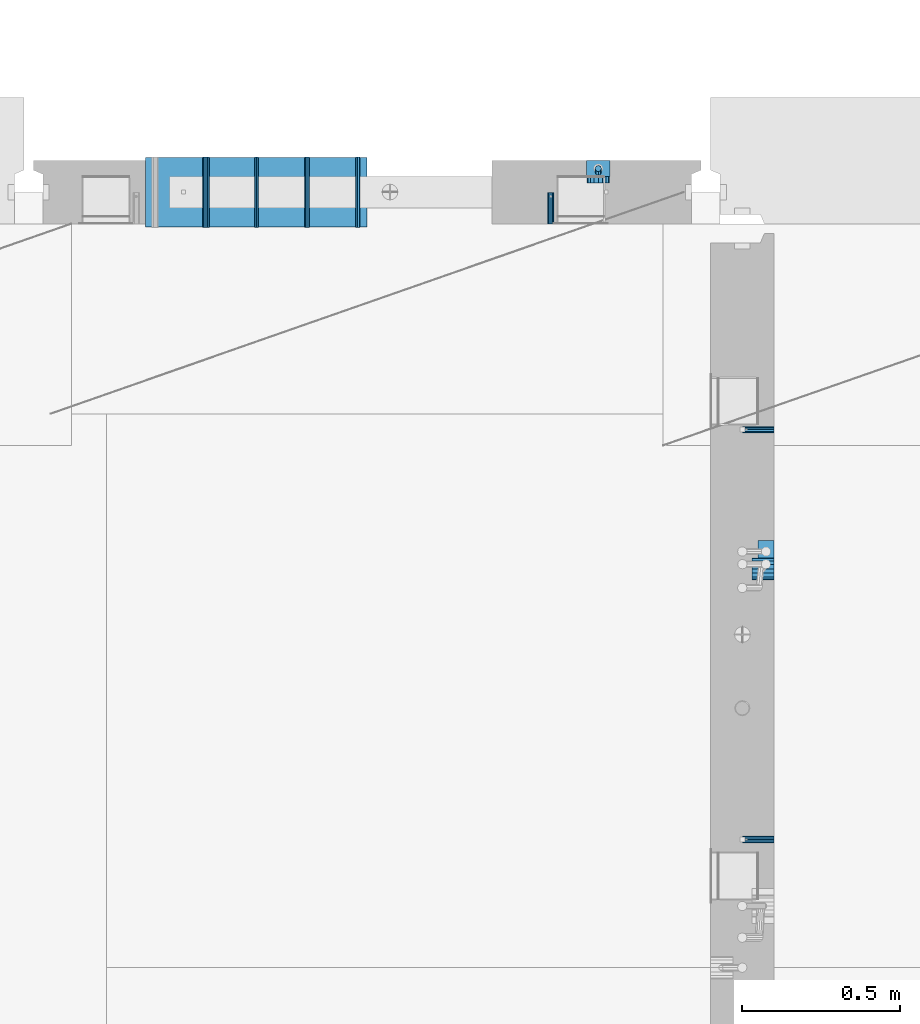
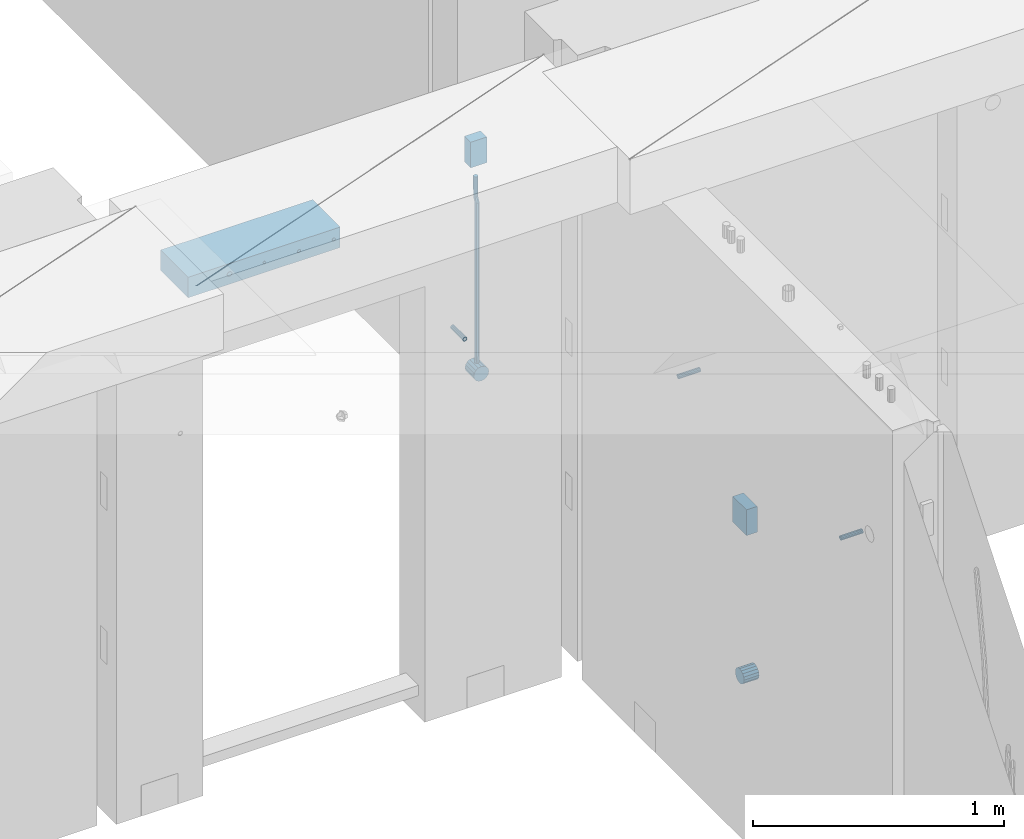
# One storey, part 125 of 309: 13 beams, 5 elements without a shape of their own.
"""IFC2X3 building model written with IfcOpenShell, lengths in millimetres."""

import ifcopenshell
import ifcopenshell.guid

model = None  # the IFC model being written
_history = None  # IfcOwnerHistory: only IFC2X3 demands one
_inside = {}  # id of a spatial element -> (the spatial element, [elements in it])
_under = {}  # id of a project, library or spatial element -> (it, [spatial elements below it])
_declared = {}  # id of a project -> (the project, [libraries it declares])
_typed = {}  # id of a type object -> (the type object, [elements of that type])
_made_of = {}  # id of a material, layer set ... -> (it, [elements and type objects made of it])


def new_model(schema):
    """Start an empty IFC model of exactly this schema.

    Asked for "IFC4X3", IfcOpenShell would pick the latest addendum, in which some entities
    have other attributes; the version numbers below select the first issue.
    IFC2X3 requires an IfcOwnerHistory on every rooted entity: one is made here for all.
    """
    global model, _history
    if schema == "IFC4X3":
        model = ifcopenshell.file(schema_version=(4, 3, 0, 0))
    else:
        model = ifcopenshell.file(schema=schema)
    _inside.clear()
    _under.clear()
    _declared.clear()
    _typed.clear()
    _made_of.clear()
    _history = None
    if model.schema == "IFC2X3":
        org = make("IfcOrganization", Name="unknown")
        user = make(
            "IfcPersonAndOrganization",
            ThePerson=make("IfcPerson", FamilyName="unknown"),
            TheOrganization=org,
        )
        app = make(
            "IfcApplication",
            ApplicationDeveloper=org,
            Version="unknown",
            ApplicationFullName="unknown",
            ApplicationIdentifier="unknown",
        )
        _history = make(
            "IfcOwnerHistory",
            OwningUser=user,
            OwningApplication=app,
            ChangeAction="ADDED",
            CreationDate=0,
        )
    return model


def make(cls, **values):
    """One entity of the class cls with the attributes given. An attribute that is None is left unset."""
    return model.create_entity(
        cls, **{name: value for name, value in values.items() if value is not None}
    )


def rooted(cls, **values):
    """An entity with a GlobalId (a new one), such as an element, a storey or a relation."""
    return make(cls, GlobalId=ifcopenshell.guid.new(), OwnerHistory=_history, **values)


def si_unit(unit_type, name, prefix=None):
    """IfcSIUnit, for example si_unit("LENGTHUNIT", "METRE", prefix="MILLI")."""
    return make("IfcSIUnit", UnitType=unit_type, Prefix=prefix, Name=name)


def assignment(units):
    """IfcUnitAssignment: the units of a project."""
    return None if units is None else make("IfcUnitAssignment", Units=units)


def point(xyz):
    """IfcCartesianPoint."""
    return None if xyz is None else make("IfcCartesianPoint", Coordinates=xyz)


def direction(xyz):
    """IfcDirection."""
    return None if xyz is None else make("IfcDirection", DirectionRatios=xyz)


def frame(location, z_axis=None, x_axis=None):
    """IfcAxis2Placement3D, a coordinate frame: its origin and axes. An axis left out is left unset."""
    return make(
        "IfcAxis2Placement3D",
        Location=point(location),
        Axis=direction(z_axis),
        RefDirection=direction(x_axis),
    )


def origin_with_axes():
    """The frame at (0, 0, 0) with the z axis (0, 0, 1) and the x axis (1, 0, 0) written out."""
    return frame((0.0, 0.0, 0.0), z_axis=(0.0, 0.0, 1.0), x_axis=(1.0, 0.0, 0.0))


def place(relative_to, where):
    """IfcLocalPlacement: puts the frame where relative to a parent placement (None: the world)."""
    return make(
        "IfcLocalPlacement", PlacementRelTo=relative_to, RelativePlacement=where
    )


def context(
    kind, dimensions, precision=None, world=None, true_north=None, identifier=None
):
    """IfcGeometricRepresentationContext, for example the 3D "Model" context."""
    return make(
        "IfcGeometricRepresentationContext",
        ContextIdentifier=identifier,
        ContextType=kind,
        CoordinateSpaceDimension=dimensions,
        Precision=precision,
        WorldCoordinateSystem=world,
        TrueNorth=true_north,
    )


def subcontext(parent, identifier, kind, view, scale=None):
    """IfcGeometricRepresentationSubContext, for example "Body" below "Model"."""
    return make(
        "IfcGeometricRepresentationSubContext",
        ContextIdentifier=identifier,
        ContextType=kind,
        ParentContext=parent,
        TargetScale=scale,
        TargetView=view,
    )


def project(units=None, contexts=None):
    """IfcProject with its units and contexts."""
    return rooted(
        "IfcProject",
        Name="project",
        RepresentationContexts=contexts,
        UnitsInContext=assignment(units),
    )


def spatial(cls, under=None, at=None, **own):
    """A site, building, storey or space (cls), placed at a placement, below another one or the project."""
    s = rooted(cls, ObjectPlacement=at, **own)
    if under is not None:
        _under.setdefault(under.id(), (under, []))[1].append(s)
    return s


def faces_of(points, faces, orient=None, outer=None):
    """IfcFace entities. A face is a list of loops; a loop is a list of indices into points, from 0.

    orient and outer hold one flag for each loop. By default every Orientation is true, the
    first loop of a face is its IfcFaceOuterBound and the others are IfcFaceBound.
    """
    made = []
    for i, loops in enumerate(faces):
        bounds = []
        for j, loop in enumerate(loops):
            is_outer = j == 0 if outer is None else outer[i][j]
            bounds.append(
                make(
                    "IfcFaceOuterBound" if is_outer else "IfcFaceBound",
                    Bound=make("IfcPolyLoop", Polygon=[points[k] for k in loop]),
                    Orientation=True if orient is None else orient[i][j],
                )
            )
        made.append(make("IfcFace", Bounds=bounds))
    return made


def faceted_brep(points, faces, orient=None, outer=None, voids=None):
    """IfcFacetedBrep: a solid bounded by flat faces; with voids (closed shells), ...WithVoids."""
    shared = [point(p) for p in points]
    hull = make("IfcClosedShell", CfsFaces=faces_of(shared, faces, orient, outer))
    if voids is None:
        return make("IfcFacetedBrep", Outer=hull)
    return make(
        "IfcFacetedBrepWithVoids",
        Outer=hull,
        Voids=[
            make(cls, CfsFaces=faces_of(shared, fs, o, b)) for cls, fs, o, b in voids
        ],
    )


def shape(context_of_items, identifier, shape_type, items):
    """IfcShapeRepresentation: the items that make up one representation, for example the "Body"."""
    return make(
        "IfcShapeRepresentation",
        ContextOfItems=context_of_items,
        RepresentationIdentifier=identifier,
        RepresentationType=shape_type,
        Items=items,
    )


def material(Name=None, Category=None):
    """IfcMaterial."""
    return make("IfcMaterial", Name=Name, Category=Category)


def made_of(thing, what):
    """Note that an element or type object is made of a material, layer set ...; save() writes the relation."""
    if what is not None:
        _made_of.setdefault(what.id(), (what, []))[1].append(thing)
    return thing


def type_object(cls, material=None, **own):
    """A type object (cls), such as IfcWallType, which elements share."""
    return made_of(rooted(cls, **own), material)


def element(
    cls,
    number,
    at=None,
    inside=None,
    cuts=None,
    type_object=None,
    material=None,
    context=None,
    identifier="Body",
    shape_type=None,
    held_by="IfcProductDefinitionShape",
    body=None,
    shapes=None,
    **own,
):
    """One element of the class cls, such as IfcWall. Its Tag is "e" and its number.

    at: its placement. inside: the storey or other place that contains it. cuts: it is an
    opening in that element (IfcRelVoidsElement). A single representation is given by context,
    identifier, shape_type and body (its items); several are given by shapes. held_by: the class
    of the entity that holds the representations. save() writes the other relations.
    """
    e = rooted(cls, Tag="e%d" % number, ObjectPlacement=at, **own)
    if body is not None:
        shapes = [shape(context, identifier, shape_type, body)]
    if shapes is not None:
        e.Representation = make(held_by, Representations=shapes)
    if inside is not None:
        _inside.setdefault(inside.id(), (inside, []))[1].append(e)
    if cuts is not None:
        rooted(
            "IfcRelVoidsElement", RelatingBuildingElement=cuts, RelatedOpeningElement=e
        )
    if type_object is not None:
        _typed.setdefault(type_object.id(), (type_object, []))[1].append(e)
    return made_of(e, material)


def aggregate(whole, parts):
    """IfcRelAggregates: a whole, such as a stair, and the parts it consists of."""
    return rooted("IfcRelAggregates", RelatingObject=whole, RelatedObjects=parts)


def save(model, path):
    """Write the relations noted so far, then the file.

    IfcRelAggregates (storeys below a building ...), IfcRelContainedInSpatialStructure (elements
    in a storey), IfcRelDefinesByType, IfcRelAssociatesMaterial and IfcRelDeclares: one each for
    every whole, place, type object, material and project.
    """
    for whole, parts in _under.values():
        aggregate(whole, parts)
    for where, things in _inside.values():
        rooted(
            "IfcRelContainedInSpatialStructure",
            RelatedElements=things,
            RelatingStructure=where,
        )
    for kind, things in _typed.values():
        rooted("IfcRelDefinesByType", RelatedObjects=things, RelatingType=kind)
    for what, things in _made_of.values():
        rooted("IfcRelAssociatesMaterial", RelatedObjects=things, RelatingMaterial=what)
    for by, libraries in _declared.values():
        rooted("IfcRelDeclares", RelatingContext=by, RelatedDefinitions=libraries)
    model.write(path)


model = new_model("IFC2X3")

# Units and contexts
model_context = context("Model", 3, precision=1e-05, world=origin_with_axes())
body_context = subcontext(model_context, "Body", "Model", "MODEL_VIEW")
ifc_project = project(units=[si_unit("LENGTHUNIT", "METRE", prefix="MILLI"), si_unit("AREAUNIT", "SQUARE_METRE"), si_unit("VOLUMEUNIT", "CUBIC_METRE"), si_unit("MASSUNIT", "GRAM", prefix="KILO"), si_unit("TIMEUNIT", "SECOND"), si_unit("PLANEANGLEUNIT", "RADIAN"), si_unit("SOLIDANGLEUNIT", "STERADIAN"), si_unit("THERMODYNAMICTEMPERATUREUNIT", "DEGREE_CELSIUS"), si_unit("LUMINOUSINTENSITYUNIT", "LUMEN")], contexts=[model_context])

# Site, building, storey
site_placement = place(None, origin_with_axes())
site = spatial("IfcSite", under=ifc_project, at=site_placement, CompositionType="ELEMENT")
building_placement = place(site_placement, origin_with_axes())
building = spatial("IfcBuilding", under=site, at=building_placement, CompositionType="ELEMENT")
storey_placement = place(building_placement, origin_with_axes())
storey = spatial("IfcBuildingStorey", under=building, at=storey_placement, Name="7", CompositionType="ELEMENT", Elevation=0.0)

# Assemblies, beams
assembly_1_placement = place(storey_placement, origin_with_axes())
assembly_1 = element("IfcElementAssembly", 1, at=assembly_1_placement, inside=storey, AssemblyPlace="NOTDEFINED", PredefinedType="REINFORCEMENT_UNIT")
assembly_2_placement = place(assembly_1_placement, origin_with_axes())
assembly_2 = element("IfcElementAssembly", 2, at=assembly_2_placement, Name="Steel Assembly", AssemblyPlace="NOTDEFINED", PredefinedType="RIGID_FRAME")
ifc_material_1 = material(Name="STEEL/Steel_Undefined")
beam_type_1 = type_object("IfcBeamType", PredefinedType="NOTDEFINED")
beam_1_placement = place(assembly_2_placement, frame((21910.0, 13134.9999119588, 101555.0), z_axis=(0.0, -1.0, 0.0), x_axis=(-1.0, 3.00000001838171e-08, 0.0)))
beam_1 = element("IfcBeam", 3, at=beam_1_placement, type_object=beam_type_1, material=ifc_material_1, Name="M16", context=body_context, shape_type="Brep", body=[
    faceted_brep([(0.0, -8.49999999999272, -1.45519152283669e-11), (0.0, -7.36121593215648, 4.24999999998545), (100.000000000262, -7.36121593215648, 4.24999999998545), (100.000000000262, -8.49999999999272, -1.45519152283669e-11), (0.0, -4.24999999998545, 7.36121593216376), (100.000000000262, -4.24999999998545, 7.36121593216376), (0.0, 1.45519152283669e-11, 8.49999999998545), (100.000000000262, 1.45519152283669e-11, 8.49999999998545), (0.0, 4.25000000001455, 7.36121593216376), (100.000000000262, 4.25000000001455, 7.36121593216376), (0.0, 7.36121593217104, 4.24999999998545), (100.000000000262, 7.36121593217104, 4.24999999998545), (0.0, 8.50000000000728, 0.0), (100.000000000262, 8.50000000000728, 0.0), (0.0, 7.36121593217104, -4.25000000001455), (100.000000000262, 7.36121593217104, -4.25000000001455), (0.0, 4.25000000000728, -7.36121593219286), (100.000000000262, 4.25000000000728, -7.36121593219286), (0.0, 7.27595761418343e-12, -8.5), (100.000000000262, 7.27595761418343e-12, -8.5), (0.0, -4.24999999999272, -7.36121593217831), (100.000000000262, -4.24999999999272, -7.36121593217831), (0.0, -7.36121593215648, -4.25), (100.000000000262, -7.36121593215648, -4.25), (0.0, -10.4999999999927, -1.45519152283669e-11), (0.0, -9.09326673972828, -5.25000000001455), (100.000000000262, -9.09326673972828, -5.25000000001455), (100.000000000262, -10.4999999999927, -1.45519152283669e-11), (0.0, -5.24999999998545, -9.09326673974283), (100.000000000262, -5.24999999998545, -9.09326673974283), (0.0, 7.27595761418343e-12, -10.5), (100.000000000262, 7.27595761418343e-12, -10.5), (0.0, 5.25000000001455, -9.09326673975738), (100.000000000262, 5.25000000001455, -9.09326673975738), (0.0, 9.09326673975011, -5.25000000001455), (100.000000000262, 9.09326673975011, -5.25000000001455), (0.0, 10.5000000000073, -1.45519152283669e-11), (100.000000000262, 10.5000000000073, -1.45519152283669e-11), (0.0, 9.09326673975011, 5.25), (100.000000000262, 9.09326673975011, 5.25), (0.0, 5.25000000000728, 9.09326673972828), (100.000000000262, 5.25000000000728, 9.09326673972828), (0.0, 1.45519152283669e-11, 10.4999999999854), (100.000000000262, 1.45519152283669e-11, 10.4999999999854), (0.0, -5.24999999999272, 9.09326673972828), (100.000000000262, -5.24999999999272, 9.09326673972828), (0.0, -9.09326673972828, 5.24999999998545), (100.000000000262, -9.09326673972828, 5.24999999998545)], [[[0, 1, 2, 3]], [[1, 4, 5, 2]], [[4, 6, 7, 5]], [[6, 8, 9, 7]], [[8, 10, 11, 9]], [[10, 12, 13, 11]], [[12, 14, 15, 13]], [[14, 16, 17, 15]], [[16, 18, 19, 17]], [[18, 20, 21, 19]], [[20, 22, 23, 21]], [[22, 0, 3, 23]], [[24, 25, 26, 27]], [[25, 28, 29, 26]], [[28, 30, 31, 29]], [[30, 32, 33, 31]], [[32, 34, 35, 33]], [[34, 36, 37, 35]], [[36, 38, 39, 37]], [[38, 40, 41, 39]], [[40, 42, 43, 41]], [[42, 44, 45, 43]], [[44, 46, 47, 45]], [[46, 24, 27, 47]], [[29, 31, 33, 35, 37, 39, 41, 43, 45, 47, 27, 26], [5, 7, 9, 11, 13, 15, 17, 19, 21, 23, 3, 2]], [[46, 44, 42, 40, 38, 36, 34, 32, 30, 28, 25, 24], [22, 20, 18, 16, 14, 12, 10, 8, 6, 4, 1, 0]]]),
])
aggregate(assembly_2, [beam_1])
assembly_3_placement = place(assembly_1_placement, origin_with_axes())
assembly_3 = element("IfcElementAssembly", 4, at=assembly_3_placement, Name="Steel Assembly", AssemblyPlace="NOTDEFINED", PredefinedType="RIGID_FRAME")
beam_2_placement = place(assembly_3_placement, frame((21910.0, 14429.9999119589, 101555.0), z_axis=(0.0, 1.0, 0.0), x_axis=(-1.0, 3.00000001838171e-08, 0.0)))
beam_2 = element("IfcBeam", 5, at=beam_2_placement, type_object=beam_type_1, material=ifc_material_1, Name="M16", context=body_context, shape_type="Brep", body=[
    faceted_brep([(0.0, -8.49999999999272, -1.45519152283669e-11), (0.0, -7.36121593215648, 4.24999999998545), (100.000000000262, -7.36121593215648, 4.24999999998545), (100.000000000262, -8.49999999999272, -1.45519152283669e-11), (0.0, -4.24999999998545, 7.36121593216376), (100.000000000262, -4.24999999998545, 7.36121593216376), (0.0, 1.45519152283669e-11, 8.49999999998545), (100.000000000262, 1.45519152283669e-11, 8.49999999998545), (0.0, 4.25000000001455, 7.36121593216376), (100.000000000262, 4.25000000001455, 7.36121593216376), (0.0, 7.36121593217104, 4.24999999998545), (100.000000000262, 7.36121593217104, 4.24999999998545), (0.0, 8.50000000000728, 0.0), (100.000000000262, 8.50000000000728, 0.0), (0.0, 7.36121593217104, -4.25000000001455), (100.000000000262, 7.36121593217104, -4.25000000001455), (0.0, 4.25000000000728, -7.36121593219286), (100.000000000262, 4.25000000000728, -7.36121593219286), (0.0, 7.27595761418343e-12, -8.5), (100.000000000262, 7.27595761418343e-12, -8.5), (0.0, -4.24999999999272, -7.36121593217831), (100.000000000262, -4.24999999999272, -7.36121593217831), (0.0, -7.36121593215648, -4.25), (100.000000000262, -7.36121593215648, -4.25), (0.0, -10.4999999999927, -1.45519152283669e-11), (0.0, -9.09326673972828, -5.25000000001455), (100.000000000262, -9.09326673972828, -5.25000000001455), (100.000000000262, -10.4999999999927, -1.45519152283669e-11), (0.0, -5.24999999998545, -9.09326673974283), (100.000000000262, -5.24999999998545, -9.09326673974283), (0.0, 7.27595761418343e-12, -10.5), (100.000000000262, 7.27595761418343e-12, -10.5), (0.0, 5.25000000001455, -9.09326673975738), (100.000000000262, 5.25000000001455, -9.09326673975738), (0.0, 9.09326673975011, -5.25000000001455), (100.000000000262, 9.09326673975011, -5.25000000001455), (0.0, 10.5000000000073, -1.45519152283669e-11), (100.000000000262, 10.5000000000073, -1.45519152283669e-11), (0.0, 9.09326673975011, 5.25), (100.000000000262, 9.09326673975011, 5.25), (0.0, 5.25000000000728, 9.09326673972828), (100.000000000262, 5.25000000000728, 9.09326673972828), (0.0, 1.45519152283669e-11, 10.4999999999854), (100.000000000262, 1.45519152283669e-11, 10.4999999999854), (0.0, -5.24999999999272, 9.09326673972828), (100.000000000262, -5.24999999999272, 9.09326673972828), (0.0, -9.09326673972828, 5.24999999998545), (100.000000000262, -9.09326673972828, 5.24999999998545)], [[[0, 1, 2, 3]], [[1, 4, 5, 2]], [[4, 6, 7, 5]], [[6, 8, 9, 7]], [[8, 10, 11, 9]], [[10, 12, 13, 11]], [[12, 14, 15, 13]], [[14, 16, 17, 15]], [[16, 18, 19, 17]], [[18, 20, 21, 19]], [[20, 22, 23, 21]], [[22, 0, 3, 23]], [[24, 25, 26, 27]], [[25, 28, 29, 26]], [[28, 30, 31, 29]], [[30, 32, 33, 31]], [[32, 34, 35, 33]], [[34, 36, 37, 35]], [[36, 38, 39, 37]], [[38, 40, 41, 39]], [[40, 42, 43, 41]], [[42, 44, 45, 43]], [[44, 46, 47, 45]], [[46, 24, 27, 47]], [[29, 31, 33, 35, 37, 39, 41, 43, 45, 47, 27, 26], [5, 7, 9, 11, 13, 15, 17, 19, 21, 23, 3, 2]], [[46, 44, 42, 40, 38, 36, 34, 32, 30, 28, 25, 24], [22, 20, 18, 16, 14, 12, 10, 8, 6, 4, 1, 0]]]),
])
aggregate(assembly_3, [beam_2])

assembly_4_placement = place(storey_placement, origin_with_axes())
assembly_4 = element("IfcElementAssembly", 6, at=assembly_4_placement, inside=storey, AssemblyPlace="NOTDEFINED", PredefinedType="REINFORCEMENT_UNIT")
assembly_5_placement = place(assembly_4_placement, origin_with_axes())
assembly_5 = element("IfcElementAssembly", 7, at=assembly_5_placement, Name="Steel Assembly", AssemblyPlace="NOTDEFINED", PredefinedType="RIGID_FRAME")
beam_3_placement = place(assembly_5_placement, frame((21205.004085231, 15080.0, 101555.0), z_axis=(1.0, 0.0, 0.0), x_axis=(0.0, 1.0, 0.0)))
beam_3 = element("IfcBeam", 8, at=beam_3_placement, type_object=beam_type_1, material=ifc_material_1, Name="M16", context=body_context, shape_type="Brep", body=[
    faceted_brep([(0.0, -8.49999999999272, -1.45519152283669e-11), (0.0, -7.36121593215648, 4.24999999998545), (100.000000000262, -7.36121593215648, 4.24999999998545), (100.000000000262, -8.49999999999272, -1.45519152283669e-11), (0.0, -4.24999999998545, 7.36121593216376), (100.000000000262, -4.24999999998545, 7.36121593216376), (0.0, 1.45519152283669e-11, 8.49999999998545), (100.000000000262, 1.45519152283669e-11, 8.49999999998545), (0.0, 4.25000000001455, 7.36121593216376), (100.000000000262, 4.25000000001455, 7.36121593216376), (0.0, 7.36121593217104, 4.24999999998545), (100.000000000262, 7.36121593217104, 4.24999999998545), (0.0, 8.50000000000728, 0.0), (100.000000000262, 8.50000000000728, 0.0), (0.0, 7.36121593217104, -4.25000000001455), (100.000000000262, 7.36121593217104, -4.25000000001455), (0.0, 4.25000000000728, -7.36121593219286), (100.000000000262, 4.25000000000728, -7.36121593219286), (0.0, 7.27595761418343e-12, -8.5), (100.000000000262, 7.27595761418343e-12, -8.5), (0.0, -4.24999999999272, -7.36121593217831), (100.000000000262, -4.24999999999272, -7.36121593217831), (0.0, -7.36121593215648, -4.25), (100.000000000262, -7.36121593215648, -4.25), (0.0, -10.4999999999927, -1.45519152283669e-11), (0.0, -9.09326673972828, -5.25000000001455), (100.000000000262, -9.09326673972828, -5.25000000001455), (100.000000000262, -10.4999999999927, -1.45519152283669e-11), (0.0, -5.24999999998545, -9.09326673974283), (100.000000000262, -5.24999999998545, -9.09326673974283), (0.0, 7.27595761418343e-12, -10.5), (100.000000000262, 7.27595761418343e-12, -10.5), (0.0, 5.25000000001455, -9.09326673975738), (100.000000000262, 5.25000000001455, -9.09326673975738), (0.0, 9.09326673975011, -5.25000000001455), (100.000000000262, 9.09326673975011, -5.25000000001455), (0.0, 10.5000000000073, -1.45519152283669e-11), (100.000000000262, 10.5000000000073, -1.45519152283669e-11), (0.0, 9.09326673975011, 5.25), (100.000000000262, 9.09326673975011, 5.25), (0.0, 5.25000000000728, 9.09326673972828), (100.000000000262, 5.25000000000728, 9.09326673972828), (0.0, 1.45519152283669e-11, 10.4999999999854), (100.000000000262, 1.45519152283669e-11, 10.4999999999854), (0.0, -5.24999999999272, 9.09326673972828), (100.000000000262, -5.24999999999272, 9.09326673972828), (0.0, -9.09326673972828, 5.24999999998545), (100.000000000262, -9.09326673972828, 5.24999999998545)], [[[0, 1, 2, 3]], [[1, 4, 5, 2]], [[4, 6, 7, 5]], [[6, 8, 9, 7]], [[8, 10, 11, 9]], [[10, 12, 13, 11]], [[12, 14, 15, 13]], [[14, 16, 17, 15]], [[16, 18, 19, 17]], [[18, 20, 21, 19]], [[20, 22, 23, 21]], [[22, 0, 3, 23]], [[24, 25, 26, 27]], [[25, 28, 29, 26]], [[28, 30, 31, 29]], [[30, 32, 33, 31]], [[32, 34, 35, 33]], [[34, 36, 37, 35]], [[36, 38, 39, 37]], [[38, 40, 41, 39]], [[40, 42, 43, 41]], [[42, 44, 45, 43]], [[44, 46, 47, 45]], [[46, 24, 27, 47]], [[29, 31, 33, 35, 37, 39, 41, 43, 45, 47, 27, 26], [5, 7, 9, 11, 13, 15, 17, 19, 21, 23, 3, 2]], [[46, 44, 42, 40, 38, 36, 34, 32, 30, 28, 25, 24], [22, 20, 18, 16, 14, 12, 10, 8, 6, 4, 1, 0]]]),
])
aggregate(assembly_5, [beam_3])
ifc_material_2 = material()
beam_type_2 = type_object("IfcBeamType", Name="D20", PredefinedType="NOTDEFINED")
beam_4_placement = place(assembly_4_placement, frame((21354.9999999958, 15245.0000022759, 101290.0), z_axis=(0.00020576299992186, -0.999642804629538, -0.0267249099901004), x_axis=(-4.30000201928125e-08, -0.0267249099948059, 0.999642825806181)))
beam_4 = element("IfcBeam", 9, at=beam_4_placement, type_object=beam_type_2, material=ifc_material_2, Name="JM20", ObjectType="D20", context=body_context, shape_type="Brep", body=[
    faceted_brep([(0.0, -10.0, 0.0), (-4.19531716033816e-08, -7.07106781186667, -7.07106781187031), (60.3581158964225, -7.07106779467358, -7.07106780560207), (60.3581159005553, -9.99999998281055, 6.26459950581193e-09), (0.0, 0.0, -10.0), (60.3581158930319, 1.71930878423154e-08, -9.9999999937354), (4.196772351861e-08, 7.07106781186303, -7.07106781186667), (60.3581158923917, 7.07106782905612, -7.07106780560207), (0.0, 10.0, 0.0), (60.3581158948509, 10.0000000171895, 6.26459950581193e-09), (4.196772351861e-08, 7.07106781185939, 7.07106781185939), (60.3581158989837, 7.07106782905612, 7.07106781813127), (0.0, 0.0, 10.0), (60.3581159023597, 1.71930878423154e-08, 10.0000000062646), (-4.19531716033816e-08, -7.07106781187031, 7.07106781185939), (60.358115903, -7.07106779467722, 7.07106781813127), (60.8972477222414, -7.07106779452079, -7.07106780554386), (60.991799419251, -9.99999998403655, 6.21366780251265e-09), (60.8581158930319, 1.7334969015792e-08, -9.99999999368447), (60.8972861483926, 7.07106782920528, -7.07106780554386), (60.9917724058905, 10.0000000159635, 6.21366780251265e-09), (61.0863241029147, 7.07106782926348, 7.07106781820403), (61.1254559321096, 1.7415004549548e-08, 10.0000000063446), (61.086285676749, -7.07106779446985, 7.07106781820403), (61.4361869218264, -7.07107072394501, -7.08547838249069), (61.6251751877571, -10.0000034255863, -0.0169367769813107), (61.35793724822, -2.69946758635342e-06, -10.0133646071736), (61.4362637644808, 7.07106489957732, -7.08547940969947), (61.6252838596702, 9.99999657411536, -0.0169382296771801), (61.8142721256008, 7.07106387247404, 7.0516033758322), (61.8925217992073, -4.15200702263974e-06, 9.97948960051872), (61.814195282961, -7.07107175104829, 7.05160440304098), (775.690073058257, -7.07495307777208, -26.1837562433175), (775.879061324187, -10.0038857794134, -19.1152146378081), (775.611823384636, -0.00388505329101463, -29.1116424680004), (775.690149900896, 7.06718254575026, -26.1837572705263), (775.8791699961, 9.99611422029193, -19.1152160905003), (776.068158262031, 7.06718151865061, -12.0466744849909), (776.146407935637, -0.00388650583045091, -9.11878826030807), (776.068081419377, -7.07495410487172, -12.0466734577822), (776.844979390982, -7.07495935530824, -26.2146370302071), (778.703176670489, -10.0039011299996, -19.1907280380728), (776.111644739809, -0.00388777008629404, -29.1250070814895), (776.932750209904, 7.0671757915552, -26.2169828873994), (778.827303353013, 9.99609819560283, -19.1940455811236), (780.685500632535, 7.06715642091513, -12.1701365889894), (781.418835283708, -0.00391516431045602, -9.25976653770704), (780.597729813613, -7.07497872594467, -12.1677907318008), (777.861329320964, -7.08852484077215, -26.7638283058368), (781.188477298943, -10.0370730804789, -20.5336763496562), (776.551501535956, -0.00975865254440578, -29.362686553719), (778.026273295982, 7.05258025600779, -26.8078751783723), (781.421743305415, 9.96146953432981, -20.595968034173), (784.74889128338, 7.01292129462308, -14.3658160779887), (786.058719068402, -0.0658448936046625, -11.7669578301065), (784.583947308391, -7.12818380215685, -14.3217692054532), (795.432392943592, -7.32305037289916, -36.2584664814858), (798.759540921557, -10.2715986126059, -30.0283145252979), (794.12256515857, -0.244284184671415, -38.8573247293643), (795.597336918581, 6.81805472388078, -36.3025133540177), (798.992806928029, 9.72694400219916, -30.0906062098184), (802.319954905994, 6.77839576249244, -23.8604542536341), (803.629782691016, -0.300370425735309, -21.2615960057519), (802.15501093099, -7.3627093342875, -23.8164073811022), (799.505846831846, -7.3774198158244, -38.4595837060842), (801.367995818946, -10.3064143349802, -31.4378100447575), (798.762755292832, -0.306218002893729, -41.3646815597422), (799.574014147365, 6.7649769840682, -38.4513366830724), (801.464398961049, 9.69395502388943, -31.4261469929661), (803.32654794812, 6.76496050473361, -24.4043733316357), (804.069639487148, -0.306241308189783, -21.4992754779851), (803.258380632629, -7.37743629515535, -24.4126203546512), (804.134608044958, -7.36363999659807, -38.5831936197719), (804.332044311042, -10.2975903644801, -31.5169642204455), (804.035512197443, -0.290521008897485, -41.5054892177468), (804.092805771987, 6.77842942390271, -38.5720098863276), (804.272926969657, 9.70231601001069, -31.5011480329304), (804.470363235741, 6.76836564212863, -24.434918633604), (804.569459083272, -0.304753345568315, -21.5126230356327), (804.512165508728, -7.37370377836123, -24.4461023670447), (901.742523775247, -7.07306129268909, -41.1897886639781), (901.939960041316, -10.0070116605639, -34.1235592646481), (901.643427927731, 5.76950078539085e-05, -44.1120842619457), (901.700721502275, 7.06900812780805, -41.1786049305338), (901.880842699946, 9.99289471391967, -34.1077430771329), (902.07827896603, 7.05894434603761, -27.0415136778065), (902.177374813546, -0.0141746416556998, -24.1192180798353), (902.120081238987, -7.08312507445589, -27.0526974112508)], [[[0, 1, 2, 3]], [[1, 4, 5, 2]], [[4, 6, 7, 5]], [[6, 8, 9, 7]], [[8, 10, 11, 9]], [[10, 12, 13, 11]], [[12, 14, 15, 13]], [[14, 0, 3, 15]], [[14, 12, 10, 8, 6, 4, 1, 0]], [[3, 2, 16, 17]], [[2, 5, 18, 16]], [[5, 7, 19, 18]], [[7, 9, 20, 19]], [[9, 11, 21, 20]], [[11, 13, 22, 21]], [[13, 15, 23, 22]], [[15, 3, 17, 23]], [[17, 16, 24, 25]], [[16, 18, 26, 24]], [[18, 19, 27, 26]], [[19, 20, 28, 27]], [[20, 21, 29, 28]], [[21, 22, 30, 29]], [[22, 23, 31, 30]], [[23, 17, 25, 31]], [[25, 24, 32, 33]], [[24, 26, 34, 32]], [[26, 27, 35, 34]], [[27, 28, 36, 35]], [[28, 29, 37, 36]], [[29, 30, 38, 37]], [[30, 31, 39, 38]], [[31, 25, 33, 39]], [[33, 32, 40, 41]], [[32, 34, 42, 40]], [[34, 35, 43, 42]], [[35, 36, 44, 43]], [[36, 37, 45, 44]], [[37, 38, 46, 45]], [[38, 39, 47, 46]], [[39, 33, 41, 47]], [[41, 40, 48, 49]], [[40, 42, 50, 48]], [[42, 43, 51, 50]], [[43, 44, 52, 51]], [[44, 45, 53, 52]], [[45, 46, 54, 53]], [[46, 47, 55, 54]], [[47, 41, 49, 55]], [[49, 48, 56, 57]], [[48, 50, 58, 56]], [[50, 51, 59, 58]], [[51, 52, 60, 59]], [[52, 53, 61, 60]], [[53, 54, 62, 61]], [[54, 55, 63, 62]], [[55, 49, 57, 63]], [[57, 56, 64, 65]], [[56, 58, 66, 64]], [[58, 59, 67, 66]], [[59, 60, 68, 67]], [[60, 61, 69, 68]], [[61, 62, 70, 69]], [[62, 63, 71, 70]], [[63, 57, 65, 71]], [[65, 64, 72, 73]], [[64, 66, 74, 72]], [[66, 67, 75, 74]], [[67, 68, 76, 75]], [[68, 69, 77, 76]], [[69, 70, 78, 77]], [[70, 71, 79, 78]], [[71, 65, 73, 79]], [[73, 72, 80, 81]], [[72, 74, 82, 80]], [[74, 75, 83, 82]], [[75, 76, 84, 83]], [[76, 77, 85, 84]], [[77, 78, 86, 85]], [[78, 79, 87, 86]], [[79, 73, 81, 87]], [[82, 83, 84, 85, 86, 87, 81, 80]]]),
])

# Beam
beam_type_3 = type_object("IfcBeamType", Name="D70", PredefinedType="NOTDEFINED")
beam_5_placement = place(assembly_1_placement, frame((21910.0000022791, 13990.0, 100355.0), z_axis=(0.0, 0.0, 1.0), x_axis=(-1.0, 3.00000001838171e-08, 0.0)))
beam_5 = element("IfcBeam", 10, at=beam_5_placement, type_object=beam_type_3, material=ifc_material_2, ObjectType="D70", context=body_context, shape_type="Brep", body=[
    faceted_brep([(0.0, -35.0, 0.0), (0.0, -32.3357836378964, -13.3939201327739), (70.0, -32.3357836378964, -13.3939201327739), (70.0, -35.0, 0.0), (0.0, -24.7487373415279, -24.7487373415352), (70.0, -24.7487373415279, -24.7487373415352), (0.0, -13.3939201327776, -32.3357836379), (70.0, -13.3939201327776, -32.3357836379), (0.0, 0.0, -35.0), (70.0, 0.0, -35.0), (0.0, 13.3939201327776, -32.3357836379), (70.0, 13.3939201327776, -32.3357836379), (0.0, 24.7487373415279, -24.7487373415352), (70.0, 24.7487373415279, -24.7487373415352), (0.0, 32.3357836378964, -13.3939201327739), (70.0, 32.3357836378964, -13.3939201327739), (0.0, 35.0, 0.0), (70.0, 35.0, 0.0), (0.0, 32.3357836378964, 13.3939201327739), (70.0, 32.3357836378964, 13.3939201327739), (0.0, 24.7487373415279, 24.7487373415352), (70.0, 24.7487373415279, 24.7487373415352), (0.0, 13.3939201327776, 32.3357836379), (70.0, 13.3939201327776, 32.3357836379), (0.0, 0.0, 35.0), (70.0, 0.0, 35.0), (0.0, -13.3939201327776, 32.3357836379), (70.0, -13.3939201327776, 32.3357836379), (0.0, -24.7487373415279, 24.7487373415352), (70.0, -24.7487373415279, 24.7487373415352), (0.0, -32.3357836378964, 13.3939201327739), (70.0, -32.3357836378964, 13.3939201327739)], [[[0, 1, 2, 3]], [[1, 4, 5, 2]], [[4, 6, 7, 5]], [[6, 8, 9, 7]], [[8, 10, 11, 9]], [[10, 12, 13, 11]], [[12, 14, 15, 13]], [[14, 16, 17, 15]], [[16, 18, 19, 17]], [[18, 20, 21, 19]], [[20, 22, 23, 21]], [[22, 24, 25, 23]], [[24, 26, 27, 25]], [[26, 28, 29, 27]], [[28, 30, 31, 29]], [[30, 0, 3, 31]], [[5, 7, 9, 11, 13, 15, 17, 19, 21, 23, 25, 27, 29, 31, 3, 2]], [[30, 28, 26, 24, 22, 20, 18, 16, 14, 12, 10, 8, 6, 4, 1, 0]]]),
])

beam_6_placement = place(assembly_4_placement, frame((21354.9999999996, 15280.0000022759, 101255.0), z_axis=(0.0, 0.0, 1.0), x_axis=(0.0, -1.0, 0.0)))
beam_6 = element("IfcBeam", 11, at=beam_6_placement, type_object=beam_type_3, material=ifc_material_2, ObjectType="D70", context=body_context, shape_type="Brep", body=[
    faceted_brep([(0.0, -35.0, 0.0), (0.0, -32.3357836378964, -13.3939201327739), (70.0, -32.3357836378964, -13.3939201327739), (70.0, -35.0, 0.0), (0.0, -24.7487373415279, -24.7487373415352), (70.0, -24.7487373415279, -24.7487373415352), (0.0, -13.3939201327776, -32.3357836379), (70.0, -13.3939201327776, -32.3357836379), (0.0, 0.0, -35.0), (70.0, 0.0, -35.0), (0.0, 13.3939201327776, -32.3357836379), (70.0, 13.3939201327776, -32.3357836379), (0.0, 24.7487373415279, -24.7487373415352), (70.0, 24.7487373415279, -24.7487373415352), (0.0, 32.3357836378964, -13.3939201327739), (70.0, 32.3357836378964, -13.3939201327739), (0.0, 35.0, 0.0), (70.0, 35.0, 0.0), (0.0, 32.3357836378964, 13.3939201327739), (70.0, 32.3357836378964, 13.3939201327739), (0.0, 24.7487373415279, 24.7487373415352), (70.0, 24.7487373415279, 24.7487373415352), (0.0, 13.3939201327776, 32.3357836379), (70.0, 13.3939201327776, 32.3357836379), (0.0, 0.0, 35.0), (70.0, 0.0, 35.0), (0.0, -13.3939201327776, 32.3357836379), (70.0, -13.3939201327776, 32.3357836379), (0.0, -24.7487373415279, 24.7487373415352), (70.0, -24.7487373415279, 24.7487373415352), (0.0, -32.3357836378964, 13.3939201327739), (70.0, -32.3357836378964, 13.3939201327739)], [[[0, 1, 2, 3]], [[1, 4, 5, 2]], [[4, 6, 7, 5]], [[6, 8, 9, 7]], [[8, 10, 11, 9]], [[10, 12, 13, 11]], [[12, 14, 15, 13]], [[14, 16, 17, 15]], [[16, 18, 19, 17]], [[18, 20, 21, 19]], [[20, 22, 23, 21]], [[22, 24, 25, 23]], [[24, 26, 27, 25]], [[26, 28, 29, 27]], [[28, 30, 31, 29]], [[30, 0, 3, 31]], [[5, 7, 9, 11, 13, 15, 17, 19, 21, 23, 25, 27, 29, 31, 3, 2]], [[30, 28, 26, 24, 22, 20, 18, 16, 14, 12, 10, 8, 6, 4, 1, 0]]]),
])

ifc_material_3 = material()
beam_type_4 = type_object("IfcBeamType", Name="D12", PredefinedType="NOTDEFINED")
beam_7_placement = place(assembly_4_placement, frame((20274.9991455079, 15068.9997314798, 102260.0), z_axis=(-1.0, 3.00000001838171e-08, 0.0), x_axis=(0.0, 1.0, 0.0)))
beam_7 = element("IfcBeam", 12, at=beam_7_placement, type_object=beam_type_4, material=ifc_material_3, Name="12", ObjectType="D12", context=body_context, shape_type="Brep", body=[
    faceted_brep([(0.0, -6.0, -1.45519152283669e-11), (0.0, -4.24264068712, -4.24264068713819), (222.000077784061, -4.24264068712364, -4.24264068712), (222.000077784061, -6.0, 0.0), (3.63797880709171e-12, 0.0, -6.0000000000291), (222.000077784061, 0.0, -6.0), (0.0, 4.24264068712, -4.24264068713819), (222.000077784061, 4.24264068712364, -4.24264068712), (0.0, 6.0, -1.45519152283669e-11), (222.000077784061, 6.0, 0.0), (0.0, 4.24264068712, 4.24264068709454), (222.000077784061, 4.24264068712364, 4.24264068712), (0.0, 0.0, 5.99999999998545), (222.000077784061, 0.0, 6.0), (0.0, -4.24264068712, 4.24264068709454), (222.000077784061, -4.24264068712364, 4.24264068712)], [[[0, 1, 2, 3]], [[1, 4, 5, 2]], [[4, 6, 7, 5]], [[6, 8, 9, 7]], [[8, 10, 11, 9]], [[10, 12, 13, 11]], [[12, 14, 15, 13]], [[14, 0, 3, 15]], [[5, 7, 9, 11, 13, 15, 3, 2]], [[14, 12, 10, 8, 6, 4, 1, 0]]]),
])

beam_type_5 = type_object("IfcBeamType", Name="D15", PredefinedType="NOTDEFINED")
beam_8_placement = place(assembly_4_placement, frame((20594.99899292, 15068.9997314793, 102260.0), z_axis=(-1.0, 3.00000001838171e-08, 0.0), x_axis=(0.0, 1.0, 0.0)))
beam_8 = element("IfcBeam", 13, at=beam_8_placement, type_object=beam_type_5, material=ifc_material_3, Name="15", ObjectType="D15", context=body_context, shape_type="Brep", body=[
    faceted_brep([(0.0, -7.5, 0.0), (0.0, -5.30330085889727, -5.30330085890091), (222.000077784061, -5.30330085889727, -5.30330085890091), (222.000077784061, -7.5, 0.0), (0.0, 1.45519152283669e-11, -7.5), (222.000077784061, 0.0, -7.5), (0.0, 5.30330085889727, -5.30330085890091), (222.000077784061, 5.30330085889727, -5.30330085890091), (0.0, 7.5, 0.0), (222.000077784061, 7.5, 0.0), (0.0, 5.30330085889727, 5.30330085890091), (222.000077784061, 5.30330085889727, 5.30330085890091), (0.0, 1.45519152283669e-11, 7.5), (222.000077784061, 0.0, 7.5), (0.0, -5.30330085889727, 5.30330085890091), (222.000077784061, -5.30330085889727, 5.30330085890091)], [[[0, 1, 2, 3]], [[1, 4, 5, 2]], [[4, 6, 7, 5]], [[6, 8, 9, 7]], [[8, 10, 11, 9]], [[10, 12, 13, 11]], [[12, 14, 15, 13]], [[14, 0, 3, 15]], [[5, 7, 9, 11, 13, 15, 3, 2]], [[14, 12, 10, 8, 6, 4, 1, 0]]]),
])

beam_9_placement = place(assembly_4_placement, frame((20434.9991455079, 15068.9997314796, 102260.0), z_axis=(-1.0, 3.00000001838171e-08, 0.0), x_axis=(0.0, 1.0, 0.0)))
beam_9 = element("IfcBeam", 14, at=beam_9_placement, type_object=beam_type_5, material=ifc_material_3, Name="15", ObjectType="D15", context=body_context, shape_type="Brep", body=[
    faceted_brep([(0.0, -7.5, 0.0), (0.0, -5.30330085889727, -5.30330085890091), (222.000077784061, -5.30330085889727, -5.30330085890091), (222.000077784061, -7.5, 0.0), (0.0, 1.45519152283669e-11, -7.5), (222.000077784061, 0.0, -7.5), (0.0, 5.30330085889727, -5.30330085890091), (222.000077784061, 5.30330085889727, -5.30330085890091), (0.0, 7.5, 0.0), (222.000077784061, 7.5, 0.0), (0.0, 5.30330085889727, 5.30330085890091), (222.000077784061, 5.30330085889727, 5.30330085890091), (0.0, 1.45519152283669e-11, 7.5), (222.000077784061, 0.0, 7.5), (0.0, -5.30330085889727, 5.30330085890091), (222.000077784061, -5.30330085889727, 5.30330085890091)], [[[0, 1, 2, 3]], [[1, 4, 5, 2]], [[4, 6, 7, 5]], [[6, 8, 9, 7]], [[8, 10, 11, 9]], [[10, 12, 13, 11]], [[12, 14, 15, 13]], [[14, 0, 3, 15]], [[5, 7, 9, 11, 13, 15, 3, 2]], [[14, 12, 10, 8, 6, 4, 1, 0]]]),
])

beam_type_6 = type_object("IfcBeamType", Name="D22", PredefinedType="NOTDEFINED")
beam_10_placement = place(assembly_4_placement, frame((20114.9991455079, 15068.9997314801, 102260.0), z_axis=(-1.0, 3.00000001838171e-08, 0.0), x_axis=(0.0, 1.0, 0.0)))
beam_10 = element("IfcBeam", 15, at=beam_10_placement, type_object=beam_type_6, material=ifc_material_3, Name="22", ObjectType="D22", context=body_context, shape_type="Brep", body=[
    faceted_brep([(0.0, -11.0, 0.0), (0.0, -9.52627944163396, -5.5), (222.000077784061, -9.52627944163396, -5.5), (222.000077784061, -11.0, 0.0), (0.0, -5.5, -9.52627944163032), (222.000077784061, -5.5, -9.52627944163032), (0.0, 0.0, -11.0), (222.000077784061, 0.0, -11.0), (0.0, 5.5, -9.52627944163032), (222.000077784061, 5.5, -9.52627944163032), (0.0, 9.52627944163396, -5.5), (222.000077784061, 9.52627944163396, -5.5), (0.0, 11.0, 0.0), (222.000077784061, 11.0, 0.0), (0.0, 9.52627944163396, 5.5), (222.000077784061, 9.52627944163396, 5.5), (0.0, 5.5, 9.52627944163032), (222.000077784061, 5.5, 9.52627944163032), (0.0, 0.0, 11.0), (222.000077784061, 0.0, 11.0), (0.0, -5.5, 9.52627944163032), (222.000077784061, -5.5, 9.52627944163032), (0.0, -9.52627944163396, 5.5), (222.000077784061, -9.52627944163396, 5.5)], [[[0, 1, 2, 3]], [[1, 4, 5, 2]], [[4, 6, 7, 5]], [[6, 8, 9, 7]], [[8, 10, 11, 9]], [[10, 12, 13, 11]], [[12, 14, 15, 13]], [[14, 16, 17, 15]], [[16, 18, 19, 17]], [[18, 20, 21, 19]], [[20, 22, 23, 21]], [[22, 0, 3, 23]], [[5, 7, 9, 11, 13, 15, 17, 19, 21, 23, 3, 2]], [[22, 20, 18, 16, 14, 12, 10, 8, 6, 4, 1, 0]]]),
])

beam_type_7 = type_object("IfcBeamType", PredefinedType="NOTDEFINED")
beam_11_placement = place(assembly_4_placement, frame((20274.9991455078, 15069.9997314811, 102260.0), z_axis=(-1.0, 3.00000001838171e-08, 0.0), x_axis=(0.0, 1.0, 0.0)))
beam_11 = element("IfcBeam", 16, at=beam_11_placement, type_object=beam_type_7, material=ifc_material_3, context=body_context, shape_type="Brep", body=[
    faceted_brep([(0.0, 50.0, -350.0), (0.0, 50.0, 350.0), (220.000077784061, 50.0, 350.0), (220.000077784061, 50.0, -350.0), (0.0, -50.0, 350.0), (220.000077784061, -50.0, 350.0), (0.0, -50.0, -350.0), (220.000077784061, -50.0, -350.0)], [[[0, 1, 2, 3]], [[1, 4, 5, 2]], [[4, 6, 7, 5]], [[6, 0, 3, 7]], [[5, 7, 3, 2]], [[6, 4, 1, 0]]]),
])

beam_type_8 = type_object("IfcBeamType", Name="125X50", PredefinedType="NOTDEFINED")
beam_12_placement = place(assembly_1_placement, frame((21885.0, 13970.0, 101105.0), z_axis=(0.0, 0.0, 1.0), x_axis=(0.0, 1.0, 0.0)))
beam_12 = element("IfcBeam", 17, at=beam_12_placement, type_object=beam_type_8, material=ifc_material_2, Name="WM2", ObjectType="125X50", context=body_context, shape_type="Brep", body=[
    faceted_brep([(0.0, 25.0, -62.5), (0.0, 25.0, 62.5), (110.0, 25.0, 62.5), (110.0, 25.0, -62.5), (0.0, -25.0, 62.5), (110.0, -25.0, 62.5), (0.0, -25.0, -62.5), (110.0, -25.0, -62.5)], [[[0, 1, 2, 3]], [[1, 4, 5, 2]], [[4, 6, 7, 5]], [[6, 0, 3, 7]], [[5, 7, 3, 2]], [[0, 6, 4, 1]]]),
])

aggregate(assembly_1, [assembly_2, assembly_3, beam_12, beam_5])

beam_13_placement = place(assembly_4_placement, frame((21392.4999999996, 15254.9999999967, 102320.0), z_axis=(0.0, 0.0, 1.0), x_axis=(-1.0, 3.00000001838171e-08, 0.0)))
beam_13 = element("IfcBeam", 18, at=beam_13_placement, type_object=beam_type_8, material=ifc_material_2, Name="WM1", ObjectType="125X50", context=body_context, shape_type="Brep", body=[
    faceted_brep([(0.0, 25.0, -62.5), (0.0, 25.0, 62.5), (75.0, 25.0, 62.5), (75.0, 25.0, -62.5), (0.0, -25.0, 62.5), (75.0, -25.0, 62.5), (0.0, -25.0, -62.5), (75.0, -25.0, -62.5)], [[[0, 1, 2, 3]], [[1, 4, 5, 2]], [[4, 6, 7, 5]], [[6, 0, 3, 7]], [[5, 7, 3, 2]], [[0, 6, 4, 1]]]),
])

aggregate(assembly_4, [assembly_5, beam_13, beam_4, beam_6, beam_10, beam_7, beam_11, beam_8, beam_9])

save(model, "model.ifc")
